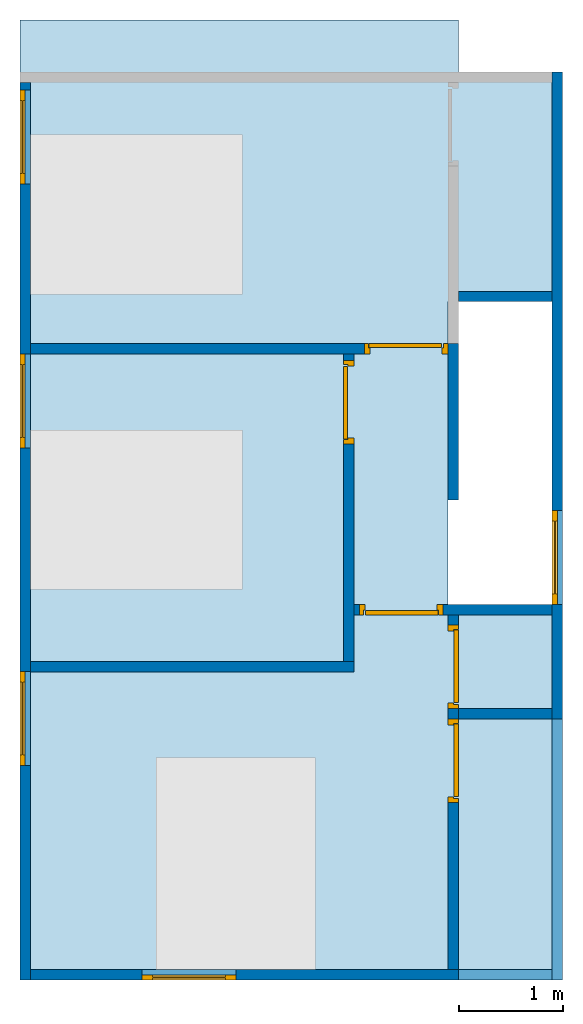
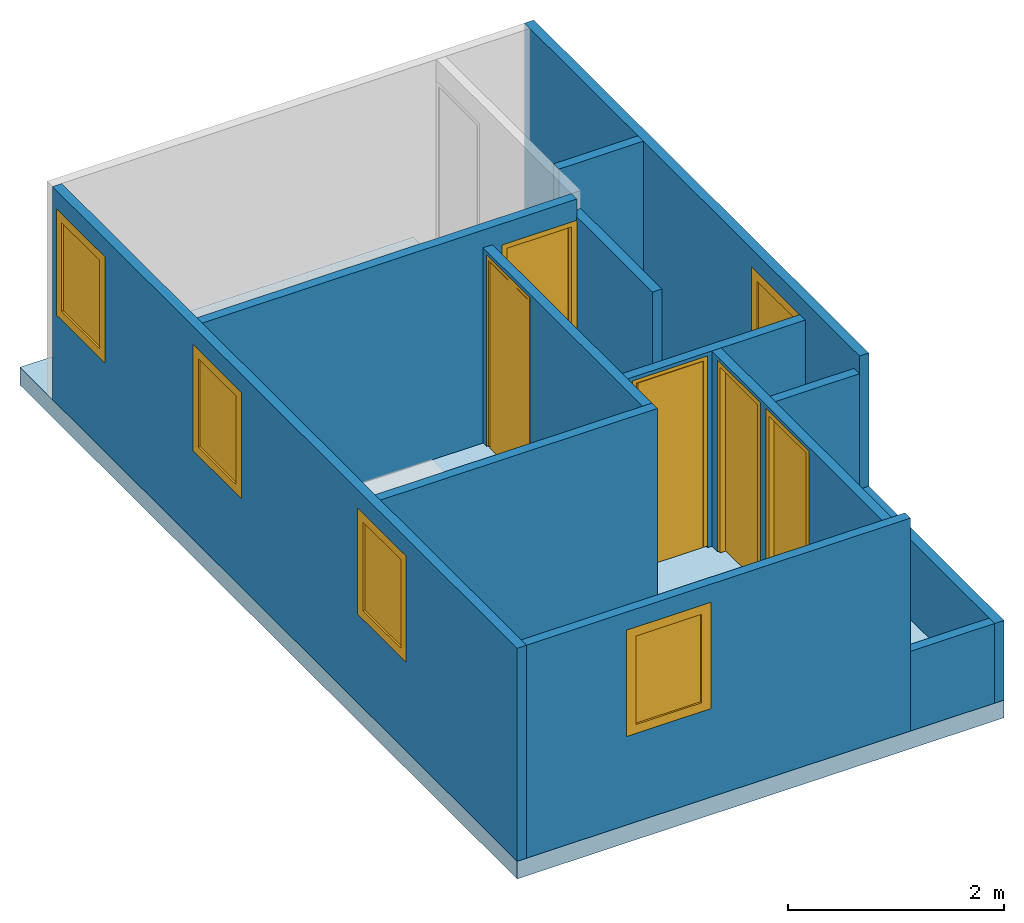
# One storey, part 1 of 3: 13 walls, 5 doors, 5 windows, 1 slab, 10 openings.
"""IFC4 building model written with IfcOpenShell, lengths in millimetres."""

from ifc_helpers import new_model, entity, si_unit, converted_unit, frame, origin_with_axes, origin_2d_with_axis, place, context, subcontext, project, spatial, line, indexed_curve, outline, extrude, polygons, source, transform, mapped, material, layer, layer_set, layer_usage, type_object, type_shapes, element, fill, save


model = new_model("IFC4")

# Units and contexts
model_context = context("Model", 3, precision=1e-05, world=origin_with_axes())
plan_context = context("Plan", 2, precision=1e-05, world=origin_2d_with_axis())
body_context = subcontext(model_context, "Body", "Model", "MODEL_VIEW")
ifc_project = project(units=[si_unit("LENGTHUNIT", "METRE", prefix="MILLI"), converted_unit("PLANEANGLEUNIT", "degree", entity("IfcReal", 0.0174532925199433), si_unit("PLANEANGLEUNIT", "RADIAN"), dimensions=[0, 0, 0, 0, 0, 0, 0]), si_unit("AREAUNIT", "SQUARE_METRE", prefix="MILLI"), si_unit("VOLUMEUNIT", "CUBIC_METRE", prefix="MILLI")], contexts=[model_context, plan_context])

# Site, building, storey
site_placement = place(None, origin_with_axes())
site = spatial("IfcSite", under=ifc_project, at=site_placement)
building_placement = place(site_placement, origin_with_axes())
building = spatial("IfcBuilding", under=site, at=building_placement, Name="Building")
storey_placement = place(building_placement, frame((0.0, 0.0, 4810.0004196167), z_axis=(0.0, 0.0, 1.0), x_axis=(1.0, 0.0, 0.0)))
storey = spatial("IfcBuildingStorey", under=building, at=storey_placement, Name="2nd FLOOR")

# Slab
ifc_material = material()
ifc_layer_1 = layer(ifc_material, 200.0)
ifc_layer_set_1 = layer_set([ifc_layer_1])
ifc_layer_usage_1 = layer_usage(ifc_layer_set_1, "AXIS3", "POSITIVE", 0.0)
slab_type = type_object("IfcSlabType", Name="FLR150", PredefinedType="NOTDEFINED", material=ifc_layer_set_1)
slab_placement = place(storey_placement, frame((-0.00351667404174805, -9199.99980926514, -199.999809265137), z_axis=(0.0, 0.0, 1.0), x_axis=(1.0, 0.0, 0.0)))
element("IfcSlab", 1, at=slab_placement, inside=storey, type_object=slab_type, material=ifc_layer_usage_1, Name="Slab", PredefinedType="NOTDEFINED", context=body_context, shape_type="SweptSolid", body=[
    extrude(outline(indexed_curve([(5200.00123977661, 3599.99442100525), (4100.0075340271, 3599.99513626099), (4100.00801086426, 6499.99523162842), (5200.00123977661, 6499.99523162842), (5200.00123977661, 8699.99504089355), (4200.00743865967, 8699.99504089355), (4200.00743865967, 9199.9979019165), (0.0, 9199.9979019165), (0.0, 0.0), (5200.00123977661, 0.0)], segments=[line(5, 4), line(4, 3), line(3, 2), line(2, 1), line(1, 10), line(10, 9), line(9, 8), line(8, 7), line(7, 6), line(6, 5)], self_intersect=False)), None, (0.0, 0.0, 1.0), 200.0),
])

# Wall, openings, windows
ifc_layer_2 = layer(ifc_material, 100.0)
ifc_layer_set_2 = layer_set([ifc_layer_2])
ifc_layer_usage_2 = layer_usage(ifc_layer_set_2, "AXIS2", "POSITIVE", 0.0)
wall_type = type_object("IfcWallType", Name="WAL100", PredefinedType="NOTDEFINED", material=ifc_layer_set_2)
wall_1_placement = place(storey_placement, frame((-9.77528529233496e-05, -600.002646446228, 0.0), z_axis=(0.0, 0.0, 1.0), x_axis=(-1.62920684942947e-07, -1.0, 0.0)))
wall_1 = element("IfcWall", 2, at=wall_1_placement, inside=storey, type_object=wall_type, material=ifc_layer_usage_2, Name="Wall", PredefinedType="NOTDEFINED", context=body_context, shape_type="SweptSolid", body=[
    extrude(outline(indexed_curve([(0.0, 0.0), (0.0, 100.0), (8599.99639821543, 100.0), (8599.99639821543, 0.0), (0.0, 0.0)], self_intersect=False)), origin_with_axes(), (0.0, 0.0, 1.0), 2405.0),
])
opening_1_placement = place(wall_1_placement, frame((70.9450832947365, -9.10154350865664e-12, 1000.0), z_axis=(0.0, 0.0, 1.0), x_axis=(1.0, 0.0, 0.0)))
opening_1 = element("IfcOpeningElement", 3, at=opening_1_placement, cuts=wall_1, Name="Opening", PredefinedType="NOTDEFINED", context=body_context, shape_type="Tessellation", body=[
    polygons([(0.0, -99.9999923706055, 0.0), (0.0, -99.9999923706055, 1200.0), (0.0, 199.999984741211, 0.0), (0.0, 199.999984741211, 1200.0), (899.999938964844, -99.9999923706055, 0.0), (899.999938964844, -99.9999923706055, 1200.0), (899.999938964844, 199.999984741211, 0.0), (899.999938964844, 199.999984741211, 1200.0)], [[[1, 2, 4, 3]], [[3, 4, 8, 7]], [[7, 8, 6, 5]], [[5, 6, 2, 1]], [[3, 7, 5, 1]], [[8, 4, 2, 6]]]),
])
opening_2_placement = place(wall_1_placement, frame((5645.71774005895, -0.000303611443141967, 1000.0), z_axis=(0.0, 0.0, 1.0), x_axis=(1.0, 0.0, 0.0)))
opening_2 = element("IfcOpeningElement", 4, at=opening_2_placement, cuts=wall_1, Name="Opening", PredefinedType="NOTDEFINED", context=body_context, shape_type="Tessellation", body=[
    polygons([(0.0, -99.9999923706055, 0.0), (0.0, -99.9999923706055, 1200.0), (0.0, 199.999984741211, 0.0), (0.0, 199.999984741211, 1200.0), (899.999938964844, -99.9999923706055, 0.0), (899.999938964844, -99.9999923706055, 1200.0), (899.999938964844, 199.999984741211, 0.0), (899.999938964844, 199.999984741211, 1200.0)], [[[1, 2, 4, 3]], [[3, 4, 8, 7]], [[7, 8, 6, 5]], [[5, 6, 2, 1]], [[3, 7, 5, 1]], [[8, 4, 2, 6]]]),
])
opening_3_placement = place(wall_1_placement, frame((2600.00026226047, -0.000188113987936, 1000.0), z_axis=(0.0, 0.0, 1.0), x_axis=(1.0, 0.0, 0.0)))
opening_3 = element("IfcOpeningElement", 5, at=opening_3_placement, cuts=wall_1, Name="Opening", PredefinedType="NOTDEFINED", context=body_context, shape_type="Tessellation", body=[
    polygons([(0.0, -99.9999923706055, 0.0), (0.0, -99.9999923706055, 1200.0), (0.0, 199.999984741211, 0.0), (0.0, 199.999984741211, 1200.0), (899.999938964844, -99.9999923706055, 0.0), (899.999938964844, -99.9999923706055, 1200.0), (899.999938964844, 199.999984741211, 0.0), (899.999938964844, 199.999984741211, 1200.0)], [[[1, 2, 4, 3]], [[3, 4, 8, 7]], [[7, 8, 6, 5]], [[5, 6, 2, 1]], [[3, 7, 5, 1]], [[8, 4, 2, 6]]]),
])
window_type = type_object("IfcWindowType", Name="WT01", PartitioningType="NOTDEFINED", PredefinedType="NOTDEFINED")
shared_shape_1 = source(origin_with_axes(), body_context, "Body", "Tessellation", [
    polygons([(899.999976158142, 0.0, 1200.00004768372), (899.999976158142, 0.0, 0.0), (0.0, 0.0, 1200.00004768372), (0.0, 0.0, 0.0), (99.9999940395355, 0.0, 99.9999940395355), (99.9999940395355, 0.0, 1100.00002384186), (800.000011920929, 0.0, 1100.00002384186), (800.000011920929, 0.0, 99.9999940395355), (99.9999940395355, 19.9999995529652, 99.9999940395355), (99.9999940395355, 19.9999995529652, 1100.00002384186), (800.000011920929, 19.9999995529652, 1100.00002384186), (800.000011920929, 19.9999995529652, 99.9999940395355), (99.9999940395355, 50.0000007450581, 99.9999940395355), (99.9999940395355, 50.0000007450581, 1100.00002384186), (800.000011920929, 50.0000007450581, 1100.00002384186), (800.000011920929, 50.0000007450581, 99.9999940395355), (0.0, 50.0000007450581, 0.0), (0.0, 50.0000007450581, 1200.00004768372), (899.999976158142, 50.0000007450581, 1200.00004768372), (899.999976158142, 50.0000007450581, 0.0), (99.9999940395355, 29.9999993294477, 99.9999940395355), (99.9999940395355, 29.9999993294477, 1100.00002384186), (800.000011920929, 29.9999993294477, 1100.00002384186), (800.000011920929, 29.9999993294477, 99.9999940395355)], [[[13, 17, 18, 14]], [[5, 6, 3, 4]], [[7, 8, 2, 1]], [[6, 7, 1, 3]], [[8, 5, 4, 2]], [[15, 19, 20, 16]], [[14, 18, 19, 15]], [[16, 20, 17, 13]], [[4, 17, 20, 2]], [[2, 20, 19, 1]], [[8, 16, 13, 5]], [[7, 15, 16, 8]], [[1, 19, 18, 3]], [[3, 18, 17, 4]], [[6, 14, 15, 7]], [[5, 13, 14, 6]]]),
    polygons([(899.999976158142, 0.0, 1200.00004768372), (899.999976158142, 0.0, 0.0), (0.0, 0.0, 1200.00004768372), (0.0, 0.0, 0.0), (99.9999940395355, 0.0, 99.9999940395355), (99.9999940395355, 0.0, 1100.00002384186), (800.000011920929, 0.0, 1100.00002384186), (800.000011920929, 0.0, 99.9999940395355), (99.9999940395355, 19.9999995529652, 99.9999940395355), (99.9999940395355, 19.9999995529652, 1100.00002384186), (800.000011920929, 19.9999995529652, 1100.00002384186), (800.000011920929, 19.9999995529652, 99.9999940395355), (99.9999940395355, 50.0000007450581, 99.9999940395355), (99.9999940395355, 50.0000007450581, 1100.00002384186), (800.000011920929, 50.0000007450581, 1100.00002384186), (800.000011920929, 50.0000007450581, 99.9999940395355), (0.0, 50.0000007450581, 0.0), (0.0, 50.0000007450581, 1200.00004768372), (899.999976158142, 50.0000007450581, 1200.00004768372), (899.999976158142, 50.0000007450581, 0.0), (99.9999940395355, 29.9999993294477, 99.9999940395355), (99.9999940395355, 29.9999993294477, 1100.00002384186), (800.000011920929, 29.9999993294477, 1100.00002384186), (800.000011920929, 29.9999993294477, 99.9999940395355)], [[[12, 11, 10, 9]], [[24, 21, 22, 23]], [[11, 23, 22, 10]], [[10, 22, 21, 9]], [[9, 21, 24, 12]], [[12, 24, 23, 11]]]),
])
type_shapes(window_type, [shared_shape_1])
window_1_placement = place(storey_placement, frame((-0.000109311272922241, -670.947730541229, 1000.0), z_axis=(0.0, 0.0, 1.0), x_axis=(-1.62920684942947e-07, -1.0, 0.0)))
window_1 = element("IfcWindow", 6, at=window_1_placement, inside=storey, type_object=window_type, Name="Window", PredefinedType="NOTDEFINED", context=body_context, shape_type="MappedRepresentation", body=[
    mapped(shared_shape_1, transform((0.0, 0.0, 0.0), x_axis=(1.0, 0.0, 0.0), y_axis=(0.0, 1.0, 0.0), z_axis=(0.0, 0.0, 1.0), scale=1.0)),
])
fill(opening_1, window_1)
window_2_placement = place(storey_placement, frame((-0.00132116849727026, -6245.72038650513, 1000.0), z_axis=(0.0, 0.0, 1.0), x_axis=(-1.62920684942947e-07, -1.0, 0.0)))
window_2 = element("IfcWindow", 7, at=window_2_placement, inside=storey, type_object=window_type, Name="Window", PredefinedType="NOTDEFINED", context=body_context, shape_type="MappedRepresentation", body=[
    mapped(shared_shape_1, transform((0.0, 0.0, 0.0), x_axis=(1.0, 0.0, 0.0), y_axis=(0.0, 1.0, 0.0), z_axis=(0.0, 0.0, 1.0), scale=1.0)),
])
fill(opening_2, window_2)
window_3_placement = place(storey_placement, frame((-0.000709460664438666, -3200.00290870667, 1000.0), z_axis=(0.0, 0.0, 1.0), x_axis=(-1.62920684942947e-07, -1.0, 0.0)))
window_3 = element("IfcWindow", 8, at=window_3_placement, inside=storey, type_object=window_type, Name="Window", PredefinedType="NOTDEFINED", context=body_context, shape_type="MappedRepresentation", body=[
    mapped(shared_shape_1, transform((0.0, 0.0, 0.0), x_axis=(1.0, 0.0, 0.0), y_axis=(0.0, 1.0, 0.0), z_axis=(0.0, 0.0, 1.0), scale=1.0)),
])
fill(opening_3, window_3)

# Wall, opening, window
ifc_layer_usage_3 = layer_usage(ifc_layer_set_2, "AXIS2", "POSITIVE", 0.0)
wall_2_placement = place(storey_placement, frame((99.9985039234161, -9199.99980926514, 0.0), z_axis=(0.0, 0.0, 1.0), x_axis=(1.0, -8.34465026855469e-07, 0.0)))
wall_2 = element("IfcWall", 9, at=wall_2_placement, inside=storey, type_object=wall_type, material=ifc_layer_usage_3, Name="Wall", PredefinedType="NOTDEFINED", context=body_context, shape_type="SweptSolid", body=[
    extrude(outline(indexed_curve([(0.0, 0.0), (0.0, 100.0), (4100.00319132044, 100.0), (4100.00319132044, 0.0), (0.0, 0.0)], self_intersect=False)), origin_with_axes(), (0.0, 0.0, 1.0), 2405.0),
])
opening_4_placement = place(wall_2_placement, frame((1069.83336806302, -6.09357861947046e-05, 1000.0), z_axis=(0.0, 0.0, 1.0), x_axis=(1.0, 0.0, 0.0)))
opening_4 = element("IfcOpeningElement", 10, at=opening_4_placement, cuts=wall_2, Name="Opening", PredefinedType="NOTDEFINED", context=body_context, shape_type="Tessellation", body=[
    polygons([(0.0, -99.9999923706055, 0.0), (0.0, -99.9999923706055, 1200.0), (0.0, 199.999984741211, 0.0), (0.0, 199.999984741211, 1200.0), (899.999938964844, -99.9999923706055, 0.0), (899.999938964844, -99.9999923706055, 1200.0), (899.999938964844, 199.999984741211, 0.0), (899.999938964844, 199.999984741211, 1200.0)], [[[1, 2, 4, 3]], [[3, 4, 8, 7]], [[7, 8, 6, 5]], [[5, 6, 2, 1]], [[3, 7, 5, 1]], [[8, 4, 2, 6]]]),
])
window_4_placement = place(storey_placement, frame((1169.83187198639, -9200.00076293945, 1000.0), z_axis=(0.0, 0.0, 1.0), x_axis=(1.0, -8.34465026855469e-07, 0.0)))
window_4 = element("IfcWindow", 11, at=window_4_placement, inside=storey, type_object=window_type, Name="Window", PredefinedType="NOTDEFINED", context=body_context, shape_type="MappedRepresentation", body=[
    mapped(shared_shape_1, transform((0.0, 0.0, 0.0), x_axis=(1.0, 0.0, 0.0), y_axis=(0.0, 1.0, 0.0), z_axis=(0.0, 0.0, 1.0), scale=1.0)),
])
fill(opening_4, window_4)

ifc_layer_usage_4 = layer_usage(ifc_layer_set_2, "AXIS2", "POSITIVE", 0.0)
wall_3_placement = place(storey_placement, frame((5100.00419616699, -500.004768371582, 0.0), z_axis=(0.0, 0.0, 1.0), x_axis=(-7.58967132696853e-07, -1.0, 0.0)))
wall_3 = element("IfcWall", 12, at=wall_3_placement, inside=storey, type_object=wall_type, material=ifc_layer_usage_4, Name="Wall", PredefinedType="NOTDEFINED", context=body_context, shape_type="SweptSolid", body=[
    extrude(outline(indexed_curve([(0.0, 0.0), (0.0, 100.0), (6199.99927397841, 100.0), (6199.99927397841, 0.0), (0.0, 0.0)], self_intersect=False)), origin_with_axes(), (0.0, 0.0, 1.0), 2405.0),
])
opening_5_placement = place(wall_3_placement, frame((4200.00028610241, -0.000150197933201923, 1000.0), z_axis=(0.0, 0.0, 1.0), x_axis=(1.0, 0.0, 0.0)))
opening_5 = element("IfcOpeningElement", 13, at=opening_5_placement, cuts=wall_3, Name="Opening", PredefinedType="NOTDEFINED", context=body_context, shape_type="Tessellation", body=[
    polygons([(0.0, -99.9999923706055, 0.0), (0.0, -99.9999923706055, 1200.0), (0.0, 199.999984741211, 0.0), (0.0, 199.999984741211, 1200.0), (899.999938964844, -99.9999923706055, 0.0), (899.999938964844, -99.9999923706055, 1200.0), (899.999938964844, 199.999984741211, 0.0), (899.999938964844, 199.999984741211, 1200.0)], [[[1, 2, 4, 3]], [[3, 4, 8, 7]], [[7, 8, 6, 5]], [[5, 6, 2, 1]], [[3, 7, 5, 1]], [[8, 4, 2, 6]]]),
])
window_5_placement = place(storey_placement, frame((5100.00085830688, -4700.00505447388, 1000.0), z_axis=(0.0, 0.0, 1.0), x_axis=(-7.58967132696853e-07, -1.0, 0.0)))
window_5 = element("IfcWindow", 14, at=window_5_placement, inside=storey, type_object=window_type, Name="Window", PredefinedType="NOTDEFINED", context=body_context, shape_type="MappedRepresentation", body=[
    mapped(shared_shape_1, transform((0.0, 0.0, 0.0), x_axis=(1.0, 0.0, 0.0), y_axis=(0.0, 1.0, 0.0), z_axis=(0.0, 0.0, 1.0), scale=1.0)),
])
fill(opening_5, window_5)

# Wall
ifc_layer_usage_5 = layer_usage(ifc_layer_set_2, "AXIS2", "POSITIVE", 0.0)
wall_4_placement = place(storey_placement, frame((5100.00324249268, -2600.00467300415, 0.0), z_axis=(0.0, 0.0, 1.0), x_axis=(-1.0, 3.89414367418794e-07, 0.0)))
element("IfcWall", 15, at=wall_4_placement, inside=storey, type_object=wall_type, material=ifc_layer_usage_5, Name="Wall", PredefinedType="NOTDEFINED", context=body_context, shape_type="SweptSolid", body=[
    extrude(outline(indexed_curve([(0.0, 0.0), (0.0, 100.0), (900.000100665648, 100.0), (900.000100665648, 0.0), (0.0, 0.0)], self_intersect=False)), origin_with_axes(), (0.0, 0.0, 1.0), 2405.0),
])

# Wall, opening, door
ifc_layer_usage_6 = layer_usage(ifc_layer_set_2, "AXIS2", "POSITIVE", 0.0)
wall_5_placement = place(storey_placement, frame((4100.00419616699, -3100.00467300415, 0.0), z_axis=(0.0, 0.0, 1.0), x_axis=(-1.0, 3.89414367418794e-07, 0.0)))
wall_5 = element("IfcWall", 16, at=wall_5_placement, inside=storey, type_object=wall_type, material=ifc_layer_usage_6, Name="Wall", PredefinedType="NOTDEFINED", context=body_context, shape_type="SweptSolid", body=[
    extrude(outline(indexed_curve([(0.0, 0.0), (0.0, 100.0), (4000.00381469575, 100.0), (4000.00381469575, 0.0), (0.0, 0.0)], self_intersect=False)), origin_with_axes(), (0.0, 0.0, 1.0), 2405.0),
])
opening_6_placement = place(wall_5_placement, frame((-0.000476837064944391, -0.000238418764730852, 0.0), z_axis=(0.0, 0.0, 1.0), x_axis=(1.0, 0.0, 0.0)))
opening_6 = element("IfcOpeningElement", 17, at=opening_6_placement, cuts=wall_5, Name="Opening", PredefinedType="NOTDEFINED", context=body_context, shape_type="Tessellation", body=[
    polygons([(0.0, -99.9999923706055, 0.0), (0.0, -99.9999923706055, 2144.99877929688), (0.0, 199.999984741211, 0.0), (0.0, 199.999984741211, 2144.99877929688), (800.0, -99.9999923706055, 0.0), (800.0, -99.9999923706055, 2144.99877929688), (800.0, 199.999984741211, 0.0), (800.0, 199.999984741211, 2144.99877929688)], [[[1, 2, 4, 3]], [[3, 4, 8, 7]], [[7, 8, 6, 5]], [[5, 6, 2, 1]], [[3, 7, 5, 1]], [[8, 4, 2, 6]]]),
])
door_type = type_object("IfcDoorType", Name="D - 800 - left swing", PredefinedType="DOOR")
shared_shape_2 = source(origin_with_axes(), body_context, "Body", "Tessellation", [
    polygons([(54.9999885559082, 54.9999694824219, 2089.9990234375), (54.9999885559082, 54.9999732971191, 0.0), (54.9999885559082, 0.0, 0.0), (54.9999885559082, 0.0, 2089.9990234375), (0.0, 0.0, 0.0), (39.9999732971191, 54.9999732971191, 0.0), (0.0, 99.9999618530273, 0.0), (39.9999732971191, 99.9999618530273, 0.0), (39.9999732971191, 99.9999618530273, 2105.0), (759.999755859375, 54.9999732971191, 2105.0), (759.999755859375, 99.9999618530273, 2105.0), (39.9999732971191, 54.9999732971191, 2105.0), (744.999877929688, 54.9999694824219, 0.0), (744.999877929688, 0.0, 2089.9990234375), (744.999877929688, 54.9999694824219, 2089.9990234375), (744.999877929688, 0.0, 0.0), (759.999755859375, 54.9999732971191, 0.0), (759.999755859375, 99.9999618530273, 0.0), (800.000061035156, 99.9999618530273, 2144.9990234375), (800.000061035156, 0.0, 2144.9990234375), (800.000061035156, 0.0, 0.0), (800.000061035156, 99.9999618530273, 0.0), (0.0, 0.0, 2144.9990234375), (0.0, 99.9999618530273, 2144.9990234375), (739.999755859375, 99.9999618530273, 2099.99877929688), (739.999755859375, 99.9999618530273, 0.0), (44.9999694824219, 99.9999618530273, 0.0), (44.9999694824219, 99.9999618530273, 2099.99877929688), (44.9999694824219, 59.9999771118164, 0.0), (44.9999694824219, 59.9999771118164, 2099.99877929688), (739.999755859375, 59.9999771118164, 2099.99877929688), (739.999755859375, 59.9999771118164, 0.0)], [[[12, 9, 11, 10]], [[13, 17, 21, 16]], [[7, 8, 6]], [[7, 6, 5]], [[13, 16, 14, 15]], [[18, 17, 10, 11]], [[10, 1, 12]], [[10, 15, 1]], [[6, 12, 1]], [[1, 2, 6]], [[17, 13, 15]], [[17, 15, 10]], [[20, 19, 24, 23]], [[14, 23, 4]], [[20, 23, 14]], [[5, 4, 23]], [[3, 4, 5]], [[21, 14, 16]], [[21, 20, 14]], [[8, 9, 12, 6]], [[11, 9, 24]], [[19, 11, 24]], [[7, 24, 9]], [[9, 8, 7]], [[22, 18, 11]], [[22, 11, 19]], [[22, 21, 17]], [[18, 22, 17]], [[6, 2, 3, 5]], [[21, 22, 19, 20]], [[5, 23, 24, 7]], [[15, 14, 4, 1]], [[4, 3, 2, 1]]]),
    polygons([(54.9999885559082, 54.9999694824219, 2089.9990234375), (54.9999885559082, 54.9999732971191, 0.0), (54.9999885559082, 0.0, 0.0), (54.9999885559082, 0.0, 2089.9990234375), (0.0, 0.0, 0.0), (39.9999732971191, 54.9999732971191, 0.0), (0.0, 99.9999618530273, 0.0), (39.9999732971191, 99.9999618530273, 0.0), (39.9999732971191, 99.9999618530273, 2105.0), (759.999755859375, 54.9999732971191, 2105.0), (759.999755859375, 99.9999618530273, 2105.0), (39.9999732971191, 54.9999732971191, 2105.0), (744.999877929688, 54.9999694824219, 0.0), (744.999877929688, 0.0, 2089.9990234375), (744.999877929688, 54.9999694824219, 2089.9990234375), (744.999877929688, 0.0, 0.0), (759.999755859375, 54.9999732971191, 0.0), (759.999755859375, 99.9999618530273, 0.0), (800.000061035156, 99.9999618530273, 2144.9990234375), (800.000061035156, 0.0, 2144.9990234375), (800.000061035156, 0.0, 0.0), (800.000061035156, 99.9999618530273, 0.0), (0.0, 0.0, 2144.9990234375), (0.0, 99.9999618530273, 2144.9990234375), (739.999755859375, 99.9999618530273, 2099.99877929688), (739.999755859375, 99.9999618530273, 0.0), (44.9999694824219, 99.9999618530273, 0.0), (44.9999694824219, 99.9999618530273, 2099.99877929688), (44.9999694824219, 59.9999771118164, 0.0), (44.9999694824219, 59.9999771118164, 2099.99877929688), (739.999755859375, 59.9999771118164, 2099.99877929688), (739.999755859375, 59.9999771118164, 0.0)], [[[27, 28, 25, 26]], [[28, 27, 29, 30]], [[31, 30, 29, 32]], [[32, 26, 25, 31]], [[25, 28, 30, 31]], [[32, 29, 27, 26]]]),
])
type_shapes(door_type, [shared_shape_2])
door_1_placement = place(storey_placement, frame((3300.00448226929, -3200.00410079956, 19.9999809265137), z_axis=(0.0, 0.0, 1.0), x_axis=(1.0, -4.76837158203125e-07, 0.0)))
door_1 = element("IfcDoor", 18, at=door_1_placement, inside=storey, type_object=door_type, Name="Door", PredefinedType="NOTDEFINED", context=body_context, shape_type="MappedRepresentation", body=[
    mapped(shared_shape_2, transform((0.0, 0.0, 0.0), x_axis=(1.0, 0.0, 0.0), y_axis=(0.0, 1.0, 0.0), z_axis=(0.0, 0.0, 1.0), scale=1.0)),
])
fill(opening_6, door_1)

ifc_layer_usage_7 = layer_usage(ifc_layer_set_2, "AXIS2", "POSITIVE", 0.0)
wall_6_placement = place(storey_placement, frame((5100.00324249268, -5600.00514984131, 0.0), z_axis=(0.0, 0.0, 1.0), x_axis=(-1.0, 3.89414367418794e-07, 0.0)))
wall_6 = element("IfcWall", 19, at=wall_6_placement, inside=storey, type_object=wall_type, material=ifc_layer_usage_7, Name="Wall", PredefinedType="NOTDEFINED", context=body_context, shape_type="SweptSolid", body=[
    extrude(outline(indexed_curve([(0.0, 0.0), (0.0, 100.0), (1899.99821562456, 100.0), (1899.99821562456, 0.0), (0.0, 0.0)], self_intersect=False)), origin_with_axes(), (0.0, 0.0, 1.0), 2205.0),
])
opening_7_placement = place(wall_6_placement, frame((1047.59025573752, -0.000545727619538638, 0.0), z_axis=(0.0, 0.0, 1.0), x_axis=(1.0, 0.0, 0.0)))
opening_7 = element("IfcOpeningElement", 20, at=opening_7_placement, cuts=wall_6, Name="Opening", PredefinedType="NOTDEFINED", context=body_context, shape_type="Tessellation", body=[
    polygons([(0.0, -99.9999923706055, 0.0), (0.0, -99.9999923706055, 2144.99877929688), (0.0, 199.999984741211, 0.0), (0.0, 199.999984741211, 2144.99877929688), (800.0, -99.9999923706055, 0.0), (800.0, -99.9999923706055, 2144.99877929688), (800.0, 199.999984741211, 0.0), (800.0, 199.999984741211, 2144.99877929688)], [[[1, 2, 4, 3]], [[3, 4, 8, 7]], [[7, 8, 6, 5]], [[5, 6, 2, 1]], [[3, 7, 5, 1]], [[8, 4, 2, 6]]]),
])
door_2_placement = place(storey_placement, frame((4052.41298675537, -5600.00419616699, 19.9999809265137), z_axis=(0.0, 0.0, 1.0), x_axis=(-1.0, 3.89414367418794e-07, 0.0)))
door_2 = element("IfcDoor", 21, at=door_2_placement, inside=storey, type_object=door_type, Name="Door", PredefinedType="NOTDEFINED", context=body_context, shape_type="MappedRepresentation", body=[
    mapped(shared_shape_2, transform((0.0, 0.0, 0.0), x_axis=(1.0, 0.0, 0.0), y_axis=(0.0, 1.0, 0.0), z_axis=(0.0, 0.0, 1.0), scale=1.0)),
])
fill(opening_7, door_2)

# Wall
ifc_layer_usage_8 = layer_usage(ifc_layer_set_2, "AXIS2", "POSITIVE", 0.0)
wall_7_placement = place(storey_placement, frame((5100.00324249268, -6600.00514984131, 0.0), z_axis=(0.0, 0.0, 1.0), x_axis=(-1.0, 3.89414367418794e-07, 0.0)))
element("IfcWall", 22, at=wall_7_placement, inside=storey, type_object=wall_type, material=ifc_layer_usage_8, Name="Wall", PredefinedType="NOTDEFINED", context=body_context, shape_type="SweptSolid", body=[
    extrude(outline(indexed_curve([(0.0, 0.0), (0.0, 100.0), (900.000564257253, 100.0), (900.000564257253, 0.0), (0.0, 0.0)], self_intersect=False)), origin_with_axes(), (0.0, 0.0, 1.0), 2205.0),
])

# Wall, openings, doors
ifc_layer_usage_9 = layer_usage(ifc_layer_set_2, "AXIS2", "POSITIVE", 0.0)
wall_8_placement = place(storey_placement, frame((4200.00123977661, -9100.00324249268, 0.0), z_axis=(0.0, 0.0, 1.0), x_axis=(5.52335052361741e-07, 1.0, 0.0)))
wall_8 = element("IfcWall", 23, at=wall_8_placement, inside=storey, type_object=wall_type, material=ifc_layer_usage_9, Name="Wall", PredefinedType="NOTDEFINED", context=body_context, shape_type="SweptSolid", body=[
    extrude(outline(indexed_curve([(0.0, 0.0), (0.0, 100.0), (3399.99823850752, 100.0), (3399.99823850752, 0.0), (0.0, 0.0)], self_intersect=False)), origin_with_axes(), (0.0, 0.0, 1.0), 2205.0),
])
opening_8_placement = place(wall_8_placement, frame((1599.99799728424, -0.000546776496967993, 0.0), z_axis=(0.0, 0.0, 1.0), x_axis=(1.0, 0.0, 0.0)))
opening_8 = element("IfcOpeningElement", 24, at=opening_8_placement, cuts=wall_8, Name="Opening", PredefinedType="NOTDEFINED", context=body_context, shape_type="Tessellation", body=[
    polygons([(0.0, -99.9999923706055, 0.0), (0.0, -99.9999923706055, 2144.99877929688), (0.0, 200.000015258789, 0.0), (0.0, 200.000015258789, 2144.99877929688), (800.0, -99.9999923706055, 0.0), (800.0, -99.9999923706055, 2144.99877929688), (800.0, 200.000015258789, 0.0), (800.0, 200.000015258789, 2144.99877929688)], [[[1, 2, 4, 3]], [[3, 4, 8, 7]], [[7, 8, 6, 5]], [[5, 6, 2, 1]], [[3, 7, 5, 1]], [[8, 4, 2, 6]]]),
])
opening_9_placement = place(wall_8_placement, frame((2499.99904632571, -4.96743703948255e-05, 0.0), z_axis=(0.0, 0.0, 1.0), x_axis=(1.0, 0.0, 0.0)))
opening_9 = element("IfcOpeningElement", 25, at=opening_9_placement, cuts=wall_8, Name="Opening", PredefinedType="NOTDEFINED", context=body_context, shape_type="Tessellation", body=[
    polygons([(0.0, -99.9999923706055, 0.0), (0.0, -99.9999923706055, 2144.99877929688), (0.0, 199.999984741211, 0.0), (0.0, 199.999984741211, 2144.99877929688), (800.0, -99.9999923706055, 0.0), (800.0, -99.9999923706055, 2144.99877929688), (800.0, 199.999984741211, 0.0), (800.0, 199.999984741211, 2144.99877929688)], [[[1, 2, 4, 3]], [[3, 4, 8, 7]], [[7, 8, 6, 5]], [[5, 6, 2, 1]], [[3, 7, 5, 1]], [[8, 4, 2, 6]]]),
])
door_3_placement = place(storey_placement, frame((4100.00324249268, -6700.00505447388, 19.9999809265137), z_axis=(0.0, 0.0, 1.0), x_axis=(-5.2054855359529e-07, -1.0, 0.0)))
door_3 = element("IfcDoor", 26, at=door_3_placement, inside=storey, type_object=door_type, Name="Door", PredefinedType="NOTDEFINED", context=body_context, shape_type="MappedRepresentation", body=[
    mapped(shared_shape_2, transform((0.0, 0.0, 0.0), x_axis=(1.0, 0.0, 0.0), y_axis=(0.0, 1.0, 0.0), z_axis=(0.0, 0.0, 1.0), scale=1.0)),
])
fill(opening_8, door_3)
door_4_placement = place(storey_placement, frame((4100.00324249268, -5800.00400543213, 19.9999809265137), z_axis=(0.0, 0.0, 1.0), x_axis=(-5.2054855359529e-07, -1.0, 0.0)))
door_4 = element("IfcDoor", 27, at=door_4_placement, inside=storey, type_object=door_type, Name="Door", PredefinedType="NOTDEFINED", context=body_context, shape_type="MappedRepresentation", body=[
    mapped(shared_shape_2, transform((0.0, 0.0, 0.0), x_axis=(1.0, 0.0, 0.0), y_axis=(0.0, 1.0, 0.0), z_axis=(0.0, 0.0, 1.0), scale=1.0)),
])
fill(opening_9, door_4)

# Wall
ifc_layer_usage_10 = layer_usage(ifc_layer_set_2, "AXIS2", "POSITIVE", 0.0)
wall_9_placement = place(storey_placement, frame((3199.99933242798, -6150.00343322754, 0.0), z_axis=(0.0, 0.0, 1.0), x_axis=(-1.0, 8.66251525621919e-07, 0.0)))
element("IfcWall", 28, at=wall_9_placement, inside=storey, type_object=wall_type, material=ifc_layer_usage_10, Name="Wall", PredefinedType="NOTDEFINED", context=body_context, shape_type="SweptSolid", body=[
    extrude(outline(indexed_curve([(0.0, 0.0), (0.0, 100.0), (3100.00009844512, 100.0), (3100.00009844512, 0.0), (0.0, 0.0)], self_intersect=False)), origin_with_axes(), (0.0, 0.0, 1.0), 2205.0),
])

# Wall, opening, door
ifc_layer_usage_11 = layer_usage(ifc_layer_set_2, "AXIS2", "POSITIVE", 0.0)
wall_10_placement = place(storey_placement, frame((3200.00433921814, -6150.00343322754, 0.0), z_axis=(0.0, 0.0, 1.0), x_axis=(9.09962921014085e-07, 1.0, 0.0)))
wall_10 = element("IfcWall", 29, at=wall_10_placement, inside=storey, type_object=wall_type, material=ifc_layer_usage_11, Name="Wall", PredefinedType="NOTDEFINED", context=body_context, shape_type="SweptSolid", body=[
    extrude(outline(indexed_curve([(0.0, 0.0), (0.0, 100.0), (2949.99908835283, 100.0), (2949.99908835283, 0.0), (0.0, 0.0)], self_intersect=False)), origin_with_axes(), (0.0, 0.0, 1.0), 2205.0),
])
opening_10_placement = place(wall_10_placement, frame((2087.62168884235, 0.0004691468551421, 0.0), z_axis=(0.0, 0.0, 1.0), x_axis=(1.0, 0.0, 0.0)))
opening_10 = element("IfcOpeningElement", 30, at=opening_10_placement, cuts=wall_10, Name="Opening", PredefinedType="NOTDEFINED", context=body_context, shape_type="Tessellation", body=[
    polygons([(0.0, -99.9999923706055, 0.0), (0.0, -99.9999923706055, 2144.99877929688), (0.0, 199.999984741211, 0.0), (0.0, 199.999984741211, 2144.99877929688), (800.0, -99.9999923706055, 0.0), (800.0, -99.9999923706055, 2144.99877929688), (800.0, 199.999984741211, 0.0), (800.0, 199.999984741211, 2144.99877929688)], [[[1, 2, 4, 3]], [[3, 4, 8, 7]], [[7, 8, 6, 5]], [[5, 6, 2, 1]], [[3, 7, 5, 1]], [[8, 4, 2, 6]]]),
])
door_5_placement = place(storey_placement, frame((3200.00576972961, -4062.38174438477, 19.9999809265137), z_axis=(0.0, 0.0, 1.0), x_axis=(9.09962921014085e-07, 1.0, 0.0)))
door_5 = element("IfcDoor", 31, at=door_5_placement, inside=storey, type_object=door_type, Name="Door", PredefinedType="NOTDEFINED", context=body_context, shape_type="MappedRepresentation", body=[
    mapped(shared_shape_2, transform((0.0, 0.0, 0.0), x_axis=(1.0, 0.0, 0.0), y_axis=(0.0, 1.0, 0.0), z_axis=(0.0, 0.0, 1.0), scale=1.0)),
])
fill(opening_10, door_5)

# Walls
ifc_layer_usage_12 = layer_usage(ifc_layer_set_2, "AXIS2", "POSITIVE", 0.0)
wall_11_placement = place(storey_placement, frame((4200.00123977661, -9200.0036239624, 0.0), z_axis=(0.0, 0.0, 1.0), x_axis=(1.0, -8.34465026855469e-07, 0.0)))
element("IfcWall", 32, at=wall_11_placement, inside=storey, type_object=wall_type, material=ifc_layer_usage_12, Name="Wall", PredefinedType="NOTDEFINED", context=body_context, shape_type="SweptSolid", body=[
    extrude(outline(indexed_curve([(0.0, 0.0), (0.0, 100.0), (899.995332282441, 100.0), (899.995332282441, 0.0), (0.0, 0.0)], self_intersect=False)), origin_with_axes(), (0.0, 0.0, 1.0), 900.0),
])
ifc_layer_usage_13 = layer_usage(ifc_layer_set_2, "AXIS2", "POSITIVE", 0.0)
wall_12_placement = place(storey_placement, frame((5099.99990463257, -6700.00410079956, 0.0), z_axis=(0.0, 0.0, 1.0), x_axis=(-7.58967132696853e-07, -1.0, 0.0)))
element("IfcWall", 33, at=wall_12_placement, inside=storey, type_object=wall_type, material=ifc_layer_usage_13, Name="Wall", PredefinedType="NOTDEFINED", context=body_context, shape_type="SweptSolid", body=[
    extrude(outline(indexed_curve([(0.0, 0.0), (0.0, 100.0), (2500.00047683784, 100.0), (2500.00047683784, 0.0), (0.0, 0.0)], self_intersect=False)), origin_with_axes(), (0.0, 0.0, 1.0), 900.0),
])
ifc_layer_usage_14 = layer_usage(ifc_layer_set_2, "AXIS2", "POSITIVE", 0.0)
wall_13_placement = place(storey_placement, frame((4200.0036239624, -4602.17189788818, 0.0), z_axis=(0.0, 0.0, 1.0), x_axis=(5.52335052361741e-07, 1.0, 0.0)))
element("IfcWall", 34, at=wall_13_placement, inside=storey, type_object=wall_type, material=ifc_layer_usage_14, Name="Wall", PredefinedType="NOTDEFINED", context=body_context, shape_type="SweptSolid", body=[
    extrude(outline(indexed_curve([(0.0, 0.0), (0.0, 100.0), (1502.16724868591, 100.0), (1502.16724868591, 0.0), (0.0, 0.0)], self_intersect=False)), origin_with_axes(), (0.0, 0.0, 1.0), 2205.0),
])

save(model, "model.ifc")
